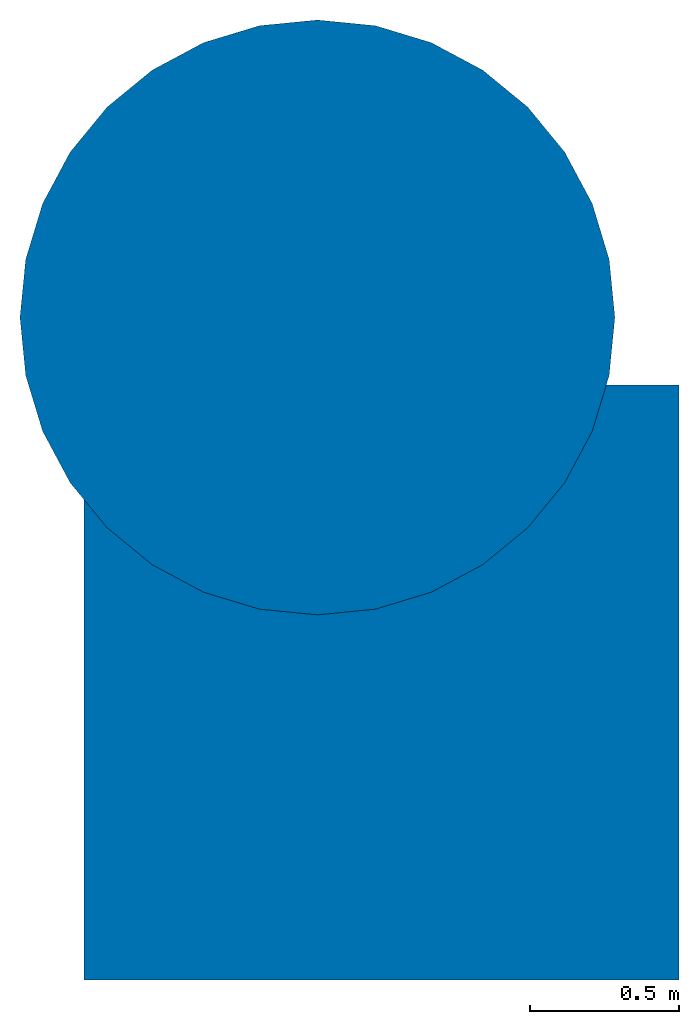
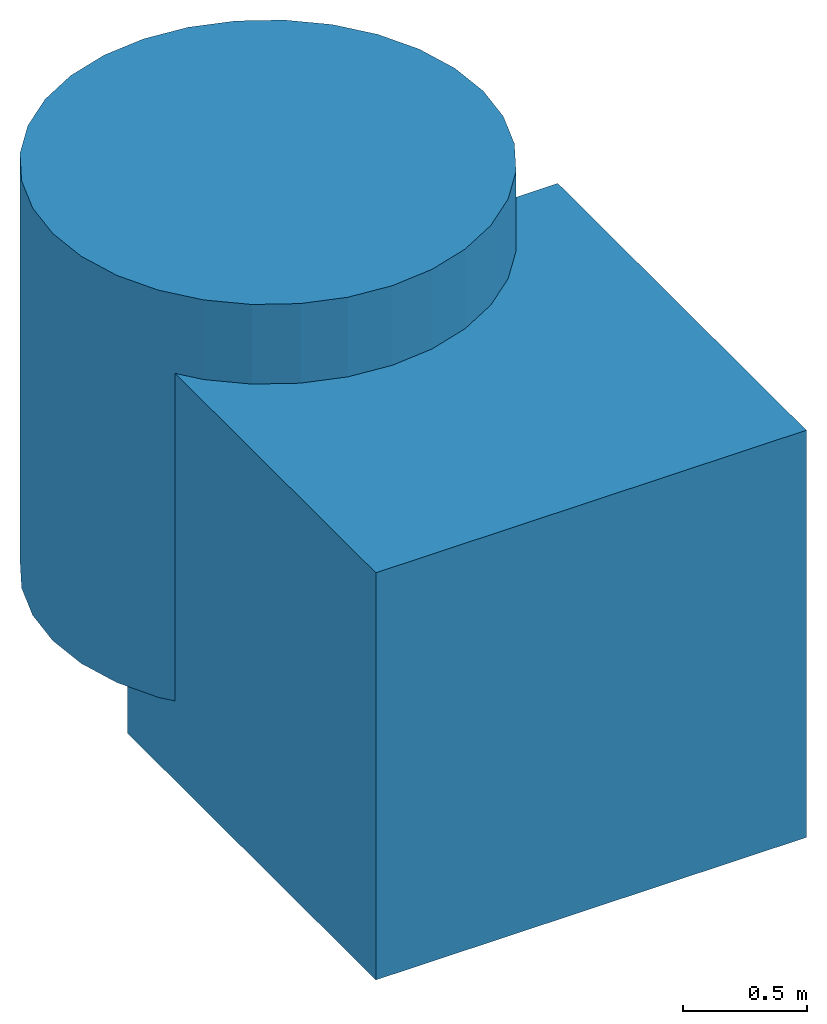
# Not in any storey: 1 column, 1 wall, 1 element without a shape of its own.
"""IFC4X3 model written with IfcOpenShell, lengths in metres."""

from ifc_helpers import new_model, entity, si_unit, converted_unit, frame, origin_with_axes, origin_2d_with_axis, place, context, subcontext, project, polygons, source, transform, mapped, type_object, type_shapes, element, aggregate, save


model = new_model("IFC4X3")

# Units and contexts
model_context = context("Model", 3, precision=1e-05, world=origin_with_axes())
plan_context = context("Plan", 2, precision=1e-05, world=origin_2d_with_axis())
body_context = subcontext(model_context, "Body", "Model", "MODEL_VIEW")
ifc_project = project(units=[converted_unit("PLANEANGLEUNIT", "degree", entity("IfcReal", 0.0174532925199433), si_unit("PLANEANGLEUNIT", "RADIAN"), dimensions=[0, 0, 0, 0, 0, 0, 0]), si_unit("AREAUNIT", "SQUARE_METRE"), si_unit("VOLUMEUNIT", "CUBIC_METRE"), si_unit("LENGTHUNIT", "METRE")], contexts=[model_context, plan_context])

# Assembly, column, wall
element_assembly_type = type_object("IfcElementAssemblyType", Name="assemblyTypeTest", PredefinedType="NOTDEFINED")
assembly_placement = place(None, origin_with_axes())
assembly = element("IfcElementAssembly", 1, at=assembly_placement, type_object=element_assembly_type, Name="test", PredefinedType="NOTDEFINED")
column_placement = place(assembly_placement, frame((-0.215055048465729, 1.22762262821198, 1.39098715782166), z_axis=(0.0, 0.0, 1.0), x_axis=(1.0, 0.0, 0.0)))
column = element("IfcColumn", 2, at=column_placement, Name="Cylinder", PredefinedType="COLUMN", context=body_context, shape_type="Tessellation", body=[
    polygons([(0.0, 1.0, -1.0), (0.0, 1.0, 1.0), (0.1950903236866, 0.980785250663757, -1.0), (0.1950903236866, 0.980785250663757, 1.0), (0.382683455944061, 0.923879504203796, -1.0), (0.382683455944061, 0.923879504203796, 1.0), (0.555570244789124, 0.831469595432281, -1.0), (0.555570244789124, 0.831469595432281, 1.0), (0.70710676908493, 0.70710676908493, -1.0), (0.70710676908493, 0.70710676908493, 1.0), (0.831469595432281, 0.555570244789124, -1.0), (0.831469595432281, 0.555570244789124, 1.0), (0.923879504203796, 0.382683455944061, -1.0), (0.923879504203796, 0.382683455944061, 1.0), (0.980785250663757, 0.1950903236866, -1.0), (0.980785250663757, 0.1950903236866, 1.0), (1.0, 0.0, -1.0), (1.0, 0.0, 1.0), (0.980785250663757, -0.1950903236866, -1.0), (0.980785250663757, -0.1950903236866, 1.0), (0.923879504203796, -0.382683455944061, -1.0), (0.923879504203796, -0.382683455944061, 1.0), (0.831469595432281, -0.555570244789124, -1.0), (0.831469595432281, -0.555570244789124, 1.0), (0.70710676908493, -0.70710676908493, -1.0), (0.70710676908493, -0.70710676908493, 1.0), (0.555570244789124, -0.831469595432281, -1.0), (0.555570244789124, -0.831469595432281, 1.0), (0.382683455944061, -0.923879504203796, -1.0), (0.382683455944061, -0.923879504203796, 1.0), (0.1950903236866, -0.980785250663757, -1.0), (0.1950903236866, -0.980785250663757, 1.0), (0.0, -1.0, -1.0), (0.0, -1.0, 1.0), (-0.1950903236866, -0.980785250663757, -1.0), (-0.1950903236866, -0.980785250663757, 1.0), (-0.382683455944061, -0.923879504203796, -1.0), (-0.382683455944061, -0.923879504203796, 1.0), (-0.555570244789124, -0.831469595432281, -1.0), (-0.555570244789124, -0.831469595432281, 1.0), (-0.70710676908493, -0.70710676908493, -1.0), (-0.70710676908493, -0.70710676908493, 1.0), (-0.831469595432281, -0.555570244789124, -1.0), (-0.831469595432281, -0.555570244789124, 1.0), (-0.923879504203796, -0.382683455944061, -1.0), (-0.923879504203796, -0.382683455944061, 1.0), (-0.980785250663757, -0.1950903236866, -1.0), (-0.980785250663757, -0.1950903236866, 1.0), (-1.0, 0.0, -1.0), (-1.0, 0.0, 1.0), (-0.980785250663757, 0.1950903236866, -1.0), (-0.980785250663757, 0.1950903236866, 1.0), (-0.923879504203796, 0.382683455944061, -1.0), (-0.923879504203796, 0.382683455944061, 1.0), (-0.831469595432281, 0.555570244789124, -1.0), (-0.831469595432281, 0.555570244789124, 1.0), (-0.70710676908493, 0.70710676908493, -1.0), (-0.70710676908493, 0.70710676908493, 1.0), (-0.555570244789124, 0.831469595432281, -1.0), (-0.555570244789124, 0.831469595432281, 1.0), (-0.382683455944061, 0.923879504203796, -1.0), (-0.382683455944061, 0.923879504203796, 1.0), (-0.1950903236866, 0.980785250663757, -1.0), (-0.1950903236866, 0.980785250663757, 1.0)], [[[1, 2, 4, 3]], [[3, 4, 6, 5]], [[5, 6, 8, 7]], [[7, 8, 10, 9]], [[9, 10, 12, 11]], [[11, 12, 14, 13]], [[13, 14, 16, 15]], [[15, 16, 18, 17]], [[17, 18, 20, 19]], [[19, 20, 22, 21]], [[21, 22, 24, 23]], [[23, 24, 26, 25]], [[25, 26, 28, 27]], [[27, 28, 30, 29]], [[29, 30, 32, 31]], [[31, 32, 34, 33]], [[33, 34, 36, 35]], [[35, 36, 38, 37]], [[37, 38, 40, 39]], [[39, 40, 42, 41]], [[41, 42, 44, 43]], [[43, 44, 46, 45]], [[45, 46, 48, 47]], [[47, 48, 50, 49]], [[49, 50, 52, 51]], [[51, 52, 54, 53]], [[53, 54, 56, 55]], [[55, 56, 58, 57]], [[57, 58, 60, 59]], [[59, 60, 62, 61]], [[4, 2, 64, 62, 60, 58, 56, 54, 52, 50, 48, 46, 44, 42, 40, 38, 36, 34, 32, 30, 28, 26, 24, 22, 20, 18, 16, 14, 12, 10, 8, 6]], [[61, 62, 64, 63]], [[63, 64, 2, 1]], [[1, 3, 5, 7, 9, 11, 13, 15, 17, 19, 21, 23, 25, 27, 29, 31, 33, 35, 37, 39, 41, 43, 45, 47, 49, 51, 53, 55, 57, 59, 61, 63]]]),
])
wall_type = type_object("IfcWallType", Name="Cube", PredefinedType="ELEMENTEDWALL")
shared_shape = source(origin_with_axes(), body_context, "Body", "Tessellation", [
    polygons([(1.0, 1.0, 1.0), (1.0, 1.0, -1.0), (1.0, -1.0, 1.0), (1.0, -1.0, -1.0), (-1.0, 1.0, 1.0), (-1.0, 1.0, -1.0), (-1.0, -1.0, 1.0), (-1.0, -1.0, -1.0)], [[[1, 5, 7, 3]], [[4, 3, 7, 8]], [[8, 7, 5, 6]], [[6, 2, 4, 8]], [[2, 1, 3, 4]], [[6, 5, 1, 2]]]),
])
type_shapes(wall_type, [shared_shape])
wall_placement = place(assembly_placement, frame((0.0, 0.0, 1.0), z_axis=(0.0, 0.0, 1.0), x_axis=(1.0, 0.0, 0.0)))
wall = element("IfcWall", 3, at=wall_placement, type_object=wall_type, Name="Wall", context=body_context, shape_type="MappedRepresentation", body=[
    mapped(shared_shape, transform((0.0, 0.0, 0.0), x_axis=(1.0, 0.0, 0.0), y_axis=(0.0, 1.0, 0.0), z_axis=(0.0, 0.0, 1.0), scale=1.0)),
])
aggregate(assembly, [wall, column])

save(model, "model.ifc")
